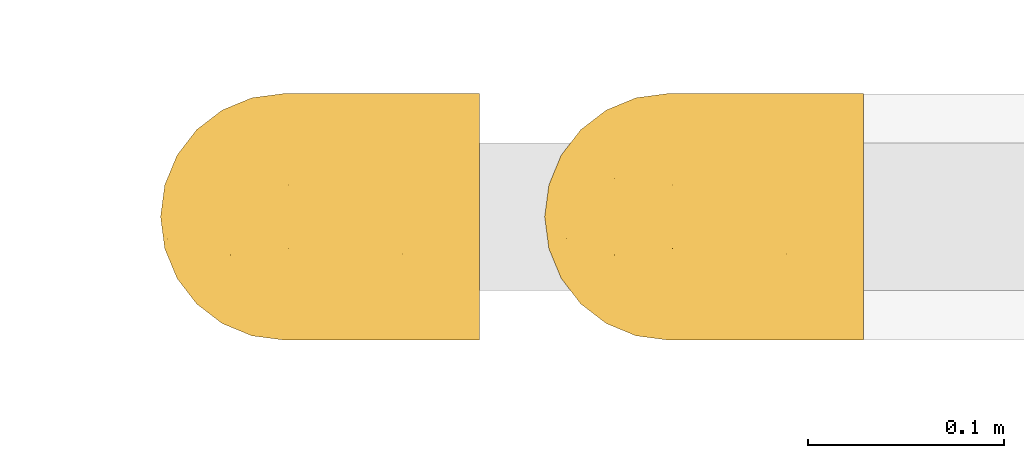
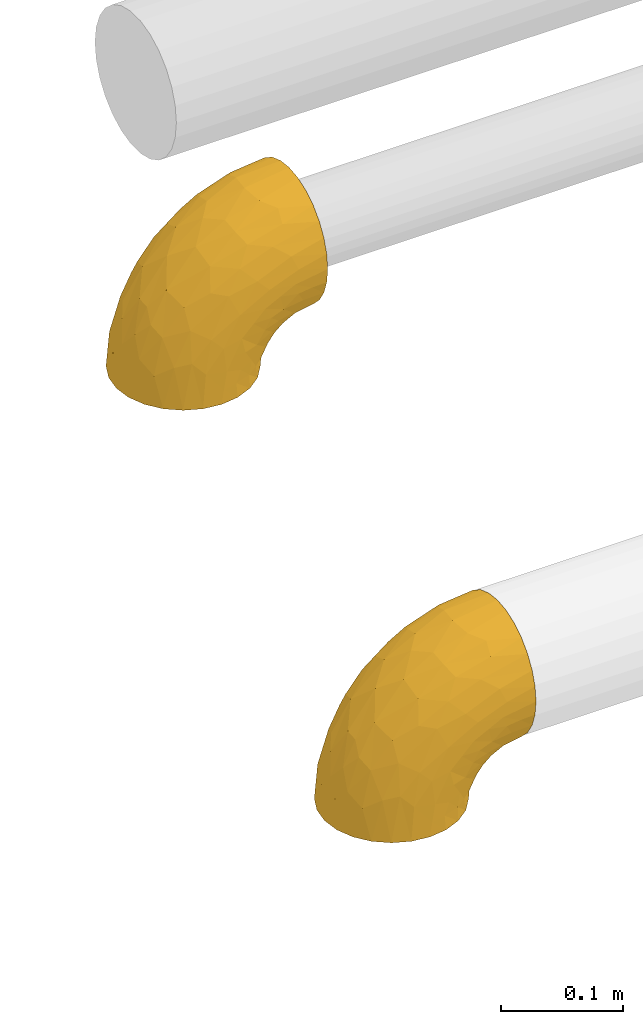
# One storey, part 119 of 827: 2 coverings.
"""IFC2X3 building model written with IfcOpenShell, lengths in millimetres."""

from ifc_helpers import new_model, entity, si_unit, converted_unit, derived_unit, direction, frame, origin, place, context, subcontext, project, spatial, faceted_brep, element, save


model = new_model("IFC2X3")

# Units and contexts
model_context = context("Model", 3, precision=0.01, world=origin(), true_north=direction((6.12303176911189e-17, 1.0)))
body_context = subcontext(model_context, "Body", "Model", "MODEL_VIEW")
ifc_project = project(units=[si_unit("LENGTHUNIT", "METRE", prefix="MILLI"), si_unit("AREAUNIT", "SQUARE_METRE"), si_unit("VOLUMEUNIT", "CUBIC_METRE"), converted_unit("PLANEANGLEUNIT", "DEGREE", entity("IfcRatioMeasure", 0.0174532925199433), si_unit("PLANEANGLEUNIT", "RADIAN"), dimensions=[0, 0, 0, 0, 0, 0, 0]), si_unit("MASSUNIT", "GRAM", prefix="KILO"), derived_unit("MASSDENSITYUNIT", [(si_unit("MASSUNIT", "GRAM", prefix="KILO"), 1), (si_unit("LENGTHUNIT", "METRE"), -3)]), derived_unit("MOMENTOFINERTIAUNIT", [(si_unit("LENGTHUNIT", "METRE"), 4)]), si_unit("TIMEUNIT", "SECOND"), si_unit("FREQUENCYUNIT", "HERTZ"), si_unit("THERMODYNAMICTEMPERATUREUNIT", "DEGREE_CELSIUS"), derived_unit("THERMALTRANSMITTANCEUNIT", [(si_unit("MASSUNIT", "GRAM", prefix="KILO"), 1), (si_unit("THERMODYNAMICTEMPERATUREUNIT", "KELVIN"), -1), (si_unit("TIMEUNIT", "SECOND"), -3)]), derived_unit("VOLUMETRICFLOWRATEUNIT", [(si_unit("LENGTHUNIT", "METRE"), 3), (si_unit("TIMEUNIT", "SECOND"), -1)]), derived_unit("MASSFLOWRATEUNIT", [(si_unit("MASSUNIT", "GRAM", prefix="KILO"), 1), (si_unit("TIMEUNIT", "SECOND"), -1)]), derived_unit("ROTATIONALFREQUENCYUNIT", [(si_unit("TIMEUNIT", "SECOND"), -1)]), si_unit("ELECTRICCURRENTUNIT", "AMPERE"), si_unit("ELECTRICVOLTAGEUNIT", "VOLT"), si_unit("POWERUNIT", "WATT"), si_unit("FORCEUNIT", "NEWTON", prefix="KILO"), si_unit("ILLUMINANCEUNIT", "LUX"), si_unit("LUMINOUSFLUXUNIT", "LUMEN"), si_unit("LUMINOUSINTENSITYUNIT", "CANDELA"), derived_unit("USERDEFINED", [(si_unit("MASSUNIT", "GRAM", prefix="KILO"), -1), (si_unit("LENGTHUNIT", "METRE"), -2), (si_unit("TIMEUNIT", "SECOND"), 3), (si_unit("LUMINOUSFLUXUNIT", "LUMEN"), 1)]), derived_unit("LINEARVELOCITYUNIT", [(si_unit("LENGTHUNIT", "METRE"), 1), (si_unit("TIMEUNIT", "SECOND"), -1)]), si_unit("PRESSUREUNIT", "PASCAL"), derived_unit("USERDEFINED", [(si_unit("LENGTHUNIT", "METRE"), -2), (si_unit("MASSUNIT", "GRAM", prefix="KILO"), 1), (si_unit("TIMEUNIT", "SECOND"), -2)]), derived_unit("LINEARFORCEUNIT", [(si_unit("MASSUNIT", "GRAM", prefix="KILO"), 1), (si_unit("LENGTHUNIT", "METRE"), 1), (si_unit("TIMEUNIT", "SECOND"), -2), (si_unit("LENGTHUNIT", "METRE"), -1)]), derived_unit("PLANARFORCEUNIT", [(si_unit("MASSUNIT", "GRAM", prefix="KILO"), 1), (si_unit("LENGTHUNIT", "METRE"), 1), (si_unit("TIMEUNIT", "SECOND"), -2), (si_unit("LENGTHUNIT", "METRE"), -2)])], contexts=[model_context])

# Site, building, storey
site_placement = place(None, origin())
site = spatial("IfcSite", under=ifc_project, at=site_placement, CompositionType="ELEMENT")
building_placement = place(site_placement, origin())
building = spatial("IfcBuilding", under=site, at=building_placement, CompositionType="ELEMENT")
storey_placement = place(building_placement, frame((0.0, 0.0, 28200.0)))
storey = spatial("IfcBuildingStorey", under=building, at=storey_placement, Name="08", CompositionType="ELEMENT", Elevation=28200.0)

# Coverings
covering_1_placement = place(storey_placement, frame((24847.71, 12005.41, 2998.4)))
element("IfcCovering", 1, at=covering_1_placement, inside=storey, Name=":ADSK_", ObjectType=":ADSK_", PredefinedType="INSULATION", context=body_context, shape_type="Brep", body=[
    faceted_brep([(164.6, 126.02, 115.61), (164.6, 121.36, 128.93), (164.6, 113.85, 140.87), (164.6, 103.88, 150.85), (164.6, 91.93, 158.35), (164.6, 78.62, 163.01), (164.6, 64.6, 164.6), (164.6, 50.58, 163.02), (164.6, 37.26, 158.36), (164.6, 25.32, 150.85), (164.6, 15.34, 140.88), (164.6, 7.84, 128.93), (164.6, 3.18, 115.62), (164.6, 1.6, 101.6), (164.6, 3.17, 87.58), (164.6, 7.83, 74.26), (164.6, 15.34, 62.32), (164.6, 25.31, 52.34), (164.6, 37.26, 44.84), (164.6, 50.57, 40.18), (164.6, 64.6, 38.6), (164.6, 78.61, 40.17), (164.6, 91.93, 44.83), (164.6, 103.87, 52.34), (164.6, 113.85, 62.31), (164.6, 121.35, 74.26), (164.6, 126.01, 87.57), (164.6, 127.6, 101.6), (96.1, 10.04, 1.6), (80.9, 3.74, 1.6), (75.83, 3.07, 1.6), (64.6, 1.6, 1.6), (48.29, 3.74, 1.6), (33.1, 10.04, 1.6), (20.05, 20.05, 1.6), (10.04, 33.1, 1.6), (3.74, 48.29, 1.6), (1.6, 64.6, 1.6), (3.74, 80.9, 1.6), (10.04, 96.1, 1.6), (20.05, 109.14, 1.6), (33.1, 119.15, 1.6), (48.29, 125.45, 1.6), (64.6, 127.6, 1.6), (75.83, 126.12, 1.6), (80.9, 125.45, 1.6), (96.1, 119.15, 1.6), (109.14, 109.14, 1.6), (119.15, 96.1, 1.6), (125.45, 80.9, 1.6), (127.6, 64.6, 1.6), (125.45, 48.29, 1.6), (119.15, 33.1, 1.6), (109.14, 20.05, 1.6), (16.11, 101.1, 30.9), (10.47, 86.73, 40.61), (25.17, 98.8, 64.38), (5.03, 75.9, 29.46), (7.15, 64.6, 43.78), (89.92, 113.69, 119.4), (63.64, 110.85, 102.55), (69.58, 99.57, 120.75), (37.4, 84.14, 98.48), (23.43, 64.6, 83.1), (49.34, 64.6, 116.85), (57.66, 122.7, 65.06), (41.13, 119.49, 45.15), (43.56, 112.73, 73.23), (51.24, 124.96, 34.45), (67.11, 126.54, 55.71), (101.38, 105.89, 134.95), (96.89, 93.87, 141.9), (127.01, 96.07, 151.53), (20.7, 87.21, 68.77), (13.5, 75.76, 60.03), (28.72, 112.0, 41.05), (122.41, 64.6, 159.04), (125.37, 83.57, 156.79), (67.01, 80.87, 129.47), (94.82, 78.22, 147.25), (76.34, 118.8, 99.9), (138.01, 126.55, 109.79), (133.22, 122.6, 122.17), (83.69, 127.6, 60.37), (76.59, 127.6, 46.44), (69.49, 127.6, 32.5), (83.16, 125.74, 83.03), (133.67, 107.12, 144.78), (119.86, 115.11, 131.77), (43.48, 102.74, 90.32), (105.82, 127.6, 82.5), (94.76, 127.6, 71.44), (150.96, 127.6, 99.44), (133.69, 127.6, 96.7), (110.48, 126.54, 99.08), (119.76, 127.6, 89.6), (101.13, 122.7, 108.53), (83.1, 64.6, 142.76), (66.76, 127.6, 15.23), (136.91, 79.61, 28.8), (142.02, 92.39, 38.73), (150.15, 78.62, 37.37), (79.29, 126.16, 16.7), (96.09, 122.25, 31.13), (87.81, 126.45, 44.73), (99.92, 123.85, 46.24), (83.57, 125.85, 28.2), (131.18, 97.8, 33.87), (123.5, 111.99, 43.22), (135.55, 104.61, 43.92), (152.5, 113.13, 60.19), (147.78, 103.95, 49.54), (137.69, 117.37, 61.42), (106.96, 124.82, 59.23), (116.2, 119.63, 51.24), (124.83, 95.72, 23.13), (122.46, 91.83, 11.1), (112.17, 109.35, 20.27), (94.66, 120.79, 16.61), (128.78, 80.16, 16.9), (130.07, 64.6, 10.85), (144.19, 122.83, 74.77), (137.7, 126.5, 85.72), (150.62, 126.15, 87.06), (146.1, 64.6, 33.64), (121.85, 121.73, 61.33), (112.08, 126.09, 70.11), (124.43, 125.23, 74.11), (157.98, 64.6, 36.82), (110.72, 116.48, 36.63), (119.91, 107.17, 31.12), (130.41, 114.56, 52.87), (153.66, 89.7, 42.37), (139.32, 64.6, 26.87), (132.55, 64.6, 20.1), (103.35, 116.12, 19.29), (112.17, 19.84, 20.28), (116.21, 9.56, 51.25), (110.7, 12.7, 36.64), (123.5, 17.2, 43.22), (128.77, 49.03, 16.9), (66.76, 1.6, 15.23), (150.15, 50.57, 37.37), (136.91, 49.58, 28.8), (137.69, 11.81, 61.43), (124.43, 3.96, 74.11), (121.85, 7.46, 61.34), (83.69, 1.6, 60.37), (76.59, 1.6, 46.44), (87.81, 2.74, 44.71), (130.41, 14.63, 52.87), (83.57, 3.34, 28.2), (96.09, 6.94, 31.13), (103.35, 13.07, 19.29), (122.46, 37.36, 11.1), (94.66, 8.4, 16.61), (79.29, 3.03, 16.7), (135.54, 24.58, 43.93), (131.17, 31.39, 33.87), (142.02, 36.79, 38.74), (153.66, 39.49, 42.37), (119.89, 22.01, 31.12), (150.96, 1.6, 99.44), (147.78, 25.23, 49.54), (112.07, 3.09, 70.12), (106.97, 4.37, 59.22), (144.19, 6.36, 74.78), (152.5, 16.06, 60.2), (124.83, 33.47, 23.13), (133.69, 1.6, 96.7), (150.62, 3.04, 87.06), (137.71, 2.69, 85.72), (105.82, 1.6, 82.5), (94.76, 1.6, 71.44), (99.9, 5.34, 46.25), (119.76, 1.6, 89.6), (69.49, 1.6, 32.5), (25.17, 30.39, 64.38), (16.11, 28.09, 30.9), (28.72, 17.19, 41.05), (41.13, 9.71, 45.15), (10.47, 42.46, 40.61), (12.64, 53.42, 57.76), (5.01, 53.33, 29.39), (67.11, 2.65, 55.71), (138.01, 2.64, 109.79), (133.22, 6.59, 122.17), (101.13, 6.49, 108.53), (63.64, 18.34, 102.55), (89.92, 15.51, 119.41), (69.57, 29.62, 120.74), (110.48, 2.65, 99.08), (83.16, 3.45, 83.03), (51.24, 4.23, 34.45), (21.38, 42.8, 70.91), (101.38, 23.3, 134.95), (133.67, 22.08, 144.78), (96.89, 35.32, 141.9), (135.87, 33.03, 153.43), (119.86, 14.08, 131.77), (43.56, 16.47, 73.23), (67.01, 48.32, 129.47), (37.4, 45.05, 98.48), (76.35, 10.39, 99.91), (57.66, 6.49, 65.06), (43.48, 26.45, 90.32), (125.37, 45.62, 156.79), (94.76, 48.44, 146.54), (23.91, 53.12, 81.81)], [[[0, 1, 2, 3, 4, 5, 6, 7, 8, 9, 10, 11, 12, 13, 14, 15, 16, 17, 18, 19, 20, 21, 22, 23, 24, 25, 26, 27]], [[28, 29, 30, 31, 32, 33, 34, 35, 36, 37, 38, 39, 40, 41, 42, 43, 44, 45, 46, 47, 48, 49, 50, 51, 52, 53]], [[54, 55, 56]], [[57, 37, 58]], [[59, 60, 61]], [[62, 63, 64]], [[65, 66, 67]], [[68, 65, 69]], [[70, 71, 72]], [[55, 73, 56]], [[39, 38, 55]], [[55, 74, 73]], [[75, 40, 54]], [[40, 39, 54]], [[76, 5, 77]], [[71, 78, 79]], [[41, 75, 66]], [[42, 68, 43]], [[59, 80, 60]], [[0, 81, 82]], [[69, 83, 84, 85]], [[69, 86, 83]], [[82, 1, 0]], [[2, 87, 3]], [[4, 3, 72]], [[40, 75, 41]], [[5, 4, 77]], [[2, 1, 88]], [[72, 3, 87]], [[5, 76, 6]], [[70, 87, 88]], [[68, 66, 65]], [[87, 2, 88]], [[56, 89, 67]], [[78, 62, 64]], [[86, 90, 91, 83]], [[81, 27, 92, 93]], [[62, 61, 89]], [[94, 93, 95, 90]], [[96, 94, 86]], [[38, 57, 55]], [[78, 61, 62]], [[82, 88, 1]], [[78, 64, 97]], [[57, 74, 55]], [[76, 77, 79]], [[77, 72, 71]], [[80, 86, 65]], [[94, 81, 93]], [[96, 88, 82]], [[79, 78, 97]], [[61, 71, 70]], [[86, 94, 90]], [[81, 96, 82]], [[68, 85, 98, 43]], [[86, 69, 65]], [[68, 69, 85]], [[66, 42, 41]], [[66, 68, 42]], [[67, 66, 75]], [[56, 67, 75]], [[67, 60, 80]], [[59, 70, 88]], [[70, 59, 61]], [[60, 67, 89]], [[78, 71, 61]], [[81, 94, 96]], [[27, 81, 0]], [[88, 96, 59]], [[80, 59, 96]], [[86, 80, 96]], [[67, 80, 65]], [[62, 89, 56]], [[61, 60, 89]], [[55, 54, 39]], [[75, 54, 56]], [[37, 57, 38]], [[74, 57, 58]], [[58, 63, 74]], [[62, 74, 63]], [[74, 62, 73]], [[62, 56, 73]], [[4, 72, 77]], [[70, 72, 87]], [[76, 79, 97]], [[71, 79, 77]], [[99, 100, 101]], [[98, 85, 102]], [[103, 104, 105]], [[106, 102, 85]], [[107, 108, 109]], [[106, 85, 84]], [[110, 111, 112]], [[105, 113, 114]], [[115, 116, 117]], [[47, 46, 118]], [[49, 119, 120]], [[48, 47, 117]], [[121, 122, 123]], [[123, 92, 26]], [[48, 116, 49]], [[124, 99, 101]], [[125, 126, 127]], [[127, 121, 112]], [[25, 24, 121]], [[101, 128, 124]], [[117, 129, 130]], [[26, 25, 123]], [[27, 26, 92]], [[131, 109, 108]], [[127, 95, 122]], [[24, 110, 121]], [[21, 20, 128]], [[131, 108, 114]], [[44, 43, 98, 45]], [[129, 114, 108]], [[23, 110, 24]], [[119, 115, 99]], [[101, 132, 21]], [[111, 23, 22]], [[90, 126, 91]], [[99, 124, 133, 134]], [[132, 111, 22]], [[128, 101, 21]], [[135, 47, 118]], [[101, 100, 132]], [[119, 99, 134]], [[107, 99, 115]], [[125, 114, 113]], [[93, 123, 122]], [[112, 125, 127]], [[129, 105, 114]], [[127, 90, 95]], [[120, 50, 49]], [[116, 119, 49]], [[111, 110, 23]], [[121, 110, 112]], [[111, 132, 100]], [[21, 132, 22]], [[125, 112, 131]], [[126, 125, 113]], [[112, 111, 131]], [[109, 111, 100]], [[111, 109, 131]], [[107, 109, 100]], [[99, 107, 100]], [[107, 115, 130]], [[126, 113, 91]], [[90, 127, 126]], [[131, 114, 125]], [[130, 129, 108]], [[135, 129, 117]], [[129, 103, 105]], [[107, 130, 108]], [[117, 130, 115]], [[121, 123, 25]], [[92, 123, 93]], [[127, 122, 121]], [[95, 93, 122]], [[117, 116, 48]], [[119, 116, 115]], [[84, 104, 106]], [[83, 113, 105]], [[103, 118, 106]], [[105, 104, 83]], [[102, 46, 45]], [[106, 104, 103]], [[83, 104, 84]], [[118, 103, 135]], [[102, 118, 46]], [[129, 135, 103]], [[47, 135, 117]], [[102, 106, 118]], [[98, 102, 45]], [[113, 83, 91]], [[119, 134, 120]], [[53, 52, 136]], [[137, 138, 139]], [[51, 120, 140]], [[141, 31, 30, 29]], [[19, 142, 128]], [[143, 134, 133, 124]], [[144, 145, 146]], [[147, 148, 149]], [[150, 144, 146]], [[151, 152, 149]], [[153, 53, 136]], [[52, 154, 136]], [[28, 155, 156]], [[143, 140, 134]], [[157, 158, 159]], [[124, 142, 143]], [[124, 128, 142]], [[18, 160, 19]], [[138, 161, 139]], [[14, 13, 162]], [[156, 141, 29]], [[159, 160, 163]], [[18, 17, 163]], [[164, 165, 146]], [[51, 154, 52]], [[166, 145, 144]], [[157, 163, 150]], [[166, 144, 167]], [[167, 17, 16]], [[16, 15, 166]], [[136, 168, 161]], [[162, 169, 170]], [[15, 14, 170]], [[167, 163, 17]], [[19, 128, 20]], [[171, 145, 166]], [[160, 159, 142]], [[155, 153, 152]], [[170, 166, 15]], [[142, 159, 143]], [[158, 143, 159]], [[140, 143, 168]], [[154, 140, 168]], [[164, 172, 173]], [[138, 174, 152]], [[150, 146, 137]], [[166, 170, 171]], [[175, 172, 145]], [[166, 167, 16]], [[163, 167, 144]], [[19, 160, 142]], [[163, 160, 18]], [[164, 146, 145]], [[137, 146, 165]], [[157, 150, 139]], [[163, 144, 150]], [[139, 161, 158]], [[163, 157, 159]], [[139, 158, 157]], [[143, 158, 168]], [[145, 172, 164]], [[164, 173, 165]], [[174, 138, 137]], [[150, 137, 139]], [[174, 137, 165]], [[153, 138, 152]], [[136, 161, 138]], [[158, 161, 168]], [[162, 170, 14]], [[170, 169, 171]], [[169, 175, 171]], [[145, 171, 175]], [[140, 154, 51]], [[136, 154, 168]], [[165, 147, 174]], [[174, 149, 152]], [[156, 151, 176]], [[151, 148, 176]], [[155, 152, 151]], [[147, 149, 174]], [[151, 149, 148]], [[156, 155, 151]], [[53, 155, 28]], [[53, 153, 155]], [[138, 153, 136]], [[141, 156, 176]], [[28, 156, 29]], [[120, 51, 50]], [[147, 165, 173]], [[120, 134, 140]], [[177, 178, 179]], [[33, 32, 180]], [[181, 182, 183]], [[184, 176, 148, 147]], [[185, 186, 187]], [[188, 189, 190]], [[191, 192, 172]], [[184, 193, 176]], [[194, 181, 177]], [[193, 180, 32]], [[37, 36, 183]], [[195, 196, 197]], [[9, 8, 198]], [[178, 181, 35]], [[36, 35, 181]], [[33, 179, 34]], [[189, 199, 195]], [[193, 31, 141, 176]], [[35, 34, 178]], [[186, 11, 199]], [[192, 147, 173, 172]], [[179, 180, 200]], [[201, 64, 202]], [[179, 200, 177]], [[13, 12, 185]], [[203, 187, 189]], [[12, 11, 186]], [[184, 192, 204]], [[203, 192, 187]], [[10, 199, 11]], [[177, 200, 205]], [[206, 198, 8]], [[207, 201, 197]], [[63, 208, 64]], [[7, 206, 8]], [[194, 182, 181]], [[7, 6, 76]], [[199, 196, 195]], [[196, 10, 9]], [[197, 196, 198]], [[7, 76, 206]], [[10, 196, 199]], [[207, 76, 97]], [[191, 172, 175, 169]], [[64, 201, 97]], [[63, 58, 182]], [[199, 187, 186]], [[187, 191, 185]], [[177, 205, 202]], [[207, 197, 206]], [[192, 184, 147]], [[193, 184, 204]], [[193, 204, 180]], [[31, 193, 32]], [[204, 203, 200]], [[33, 180, 179]], [[204, 200, 180]], [[200, 188, 205]], [[191, 169, 185]], [[192, 191, 187]], [[190, 195, 197]], [[195, 190, 189]], [[197, 201, 190]], [[202, 190, 201]], [[185, 169, 162, 13]], [[186, 185, 12]], [[203, 189, 188]], [[187, 199, 189]], [[200, 203, 188]], [[192, 203, 204]], [[188, 190, 205]], [[202, 205, 190]], [[179, 178, 34]], [[181, 178, 177]], [[177, 202, 194]], [[182, 208, 63]], [[182, 194, 208]], [[183, 182, 58]], [[37, 183, 58]], [[181, 183, 36]], [[194, 202, 208]], [[64, 208, 202]], [[197, 198, 206]], [[9, 198, 196]], [[76, 207, 206]], [[97, 201, 207]]]),
])
covering_2_placement = place(storey_placement, frame((25044.13, 12005.41, 2498.4)))
element("IfcCovering", 2, at=covering_2_placement, inside=storey, Name=":ADSK_", ObjectType=":ADSK_", PredefinedType="INSULATION", context=body_context, shape_type="Brep", body=[
    faceted_brep([(164.6, 126.02, 115.61), (164.6, 121.36, 128.93), (164.6, 113.85, 140.87), (164.6, 103.88, 150.85), (164.6, 91.93, 158.35), (164.6, 78.62, 163.01), (164.6, 64.6, 164.6), (164.6, 50.58, 163.02), (164.6, 37.26, 158.36), (164.6, 25.32, 150.85), (164.6, 15.34, 140.88), (164.6, 7.84, 128.93), (164.6, 3.18, 115.62), (164.6, 1.6, 101.6), (164.6, 3.17, 87.58), (164.6, 7.83, 74.26), (164.6, 15.34, 62.32), (164.6, 25.31, 52.34), (164.6, 37.26, 44.84), (164.6, 50.57, 40.18), (164.6, 64.6, 38.6), (164.6, 78.61, 40.17), (164.6, 91.93, 44.83), (164.6, 103.87, 52.34), (164.6, 113.85, 62.31), (164.6, 121.35, 74.26), (164.6, 126.01, 87.57), (164.6, 127.6, 101.6), (96.1, 10.04, 1.6), (80.9, 3.74, 1.6), (75.83, 3.07, 1.6), (64.6, 1.6, 1.6), (48.29, 3.74, 1.6), (33.1, 10.04, 1.6), (20.05, 20.05, 1.6), (10.04, 33.1, 1.6), (3.74, 48.29, 1.6), (1.6, 64.6, 1.6), (3.74, 80.9, 1.6), (10.04, 96.1, 1.6), (20.05, 109.14, 1.6), (33.1, 119.15, 1.6), (48.29, 125.45, 1.6), (64.6, 127.6, 1.6), (75.83, 126.12, 1.6), (80.9, 125.45, 1.6), (96.1, 119.15, 1.6), (109.14, 109.14, 1.6), (119.15, 96.1, 1.6), (125.45, 80.9, 1.6), (127.6, 64.6, 1.6), (125.45, 48.29, 1.6), (119.15, 33.1, 1.6), (109.14, 20.05, 1.6), (16.11, 101.1, 30.9), (10.47, 86.73, 40.61), (25.17, 98.8, 64.38), (5.03, 75.9, 29.46), (7.15, 64.6, 43.78), (89.92, 113.69, 119.4), (63.64, 110.85, 102.55), (69.58, 99.57, 120.75), (37.4, 84.14, 98.48), (23.43, 64.6, 83.1), (49.34, 64.6, 116.85), (57.66, 122.7, 65.06), (41.13, 119.49, 45.15), (43.56, 112.73, 73.23), (51.24, 124.96, 34.45), (67.11, 126.54, 55.71), (101.38, 105.89, 134.95), (96.89, 93.87, 141.9), (127.01, 96.07, 151.53), (20.7, 87.21, 68.77), (13.5, 75.76, 60.03), (28.72, 112.0, 41.05), (122.41, 64.6, 159.04), (125.37, 83.57, 156.79), (67.01, 80.87, 129.47), (94.82, 78.22, 147.25), (76.34, 118.8, 99.9), (138.01, 126.55, 109.79), (133.22, 122.6, 122.17), (83.69, 127.6, 60.37), (76.59, 127.6, 46.44), (69.49, 127.6, 32.5), (83.16, 125.74, 83.03), (133.67, 107.12, 144.78), (119.86, 115.11, 131.77), (43.48, 102.74, 90.32), (105.82, 127.6, 82.5), (94.76, 127.6, 71.44), (150.96, 127.6, 99.44), (133.69, 127.6, 96.7), (110.48, 126.54, 99.08), (119.76, 127.6, 89.6), (101.13, 122.7, 108.53), (83.1, 64.6, 142.76), (66.76, 127.6, 15.23), (136.91, 79.61, 28.8), (142.02, 92.39, 38.73), (150.15, 78.62, 37.37), (79.29, 126.16, 16.7), (96.09, 122.25, 31.13), (87.81, 126.45, 44.73), (99.92, 123.85, 46.24), (83.57, 125.85, 28.2), (131.18, 97.8, 33.87), (123.5, 111.99, 43.22), (135.55, 104.61, 43.92), (152.5, 113.13, 60.19), (147.78, 103.95, 49.54), (137.69, 117.37, 61.42), (106.96, 124.82, 59.23), (116.2, 119.63, 51.24), (124.83, 95.72, 23.13), (122.46, 91.83, 11.1), (112.17, 109.35, 20.27), (94.66, 120.79, 16.61), (128.78, 80.16, 16.9), (130.07, 64.6, 10.85), (144.19, 122.83, 74.77), (137.7, 126.5, 85.72), (150.62, 126.15, 87.06), (146.1, 64.6, 33.64), (121.85, 121.73, 61.33), (112.08, 126.09, 70.11), (124.43, 125.23, 74.11), (157.98, 64.6, 36.82), (110.72, 116.48, 36.63), (119.91, 107.17, 31.12), (130.41, 114.56, 52.87), (153.66, 89.7, 42.37), (139.32, 64.6, 26.87), (132.55, 64.6, 20.1), (103.35, 116.12, 19.29), (112.17, 19.84, 20.28), (116.21, 9.56, 51.25), (110.7, 12.7, 36.64), (123.5, 17.2, 43.22), (128.77, 49.03, 16.9), (66.76, 1.6, 15.23), (150.15, 50.57, 37.37), (136.91, 49.58, 28.8), (137.69, 11.81, 61.43), (124.43, 3.96, 74.11), (121.85, 7.46, 61.34), (83.69, 1.6, 60.37), (76.59, 1.6, 46.44), (87.81, 2.74, 44.71), (130.41, 14.63, 52.87), (83.57, 3.34, 28.2), (96.09, 6.94, 31.13), (103.35, 13.07, 19.29), (122.46, 37.36, 11.1), (94.66, 8.4, 16.61), (79.29, 3.03, 16.7), (135.54, 24.58, 43.93), (131.17, 31.39, 33.87), (142.02, 36.79, 38.74), (153.66, 39.49, 42.37), (119.89, 22.01, 31.12), (150.96, 1.6, 99.44), (147.78, 25.23, 49.54), (112.07, 3.09, 70.12), (106.97, 4.37, 59.22), (144.19, 6.36, 74.78), (152.5, 16.06, 60.2), (124.83, 33.47, 23.13), (133.69, 1.6, 96.7), (150.62, 3.04, 87.06), (137.71, 2.69, 85.72), (105.82, 1.6, 82.5), (94.76, 1.6, 71.44), (99.9, 5.34, 46.25), (119.76, 1.6, 89.6), (69.49, 1.6, 32.5), (25.17, 30.39, 64.38), (16.11, 28.09, 30.9), (28.72, 17.19, 41.05), (41.13, 9.71, 45.15), (10.47, 42.46, 40.61), (12.64, 53.42, 57.76), (5.01, 53.33, 29.39), (67.11, 2.65, 55.71), (138.01, 2.64, 109.79), (133.22, 6.59, 122.17), (101.13, 6.49, 108.53), (63.64, 18.34, 102.55), (89.92, 15.51, 119.41), (69.57, 29.62, 120.74), (110.48, 2.65, 99.08), (83.16, 3.45, 83.03), (51.24, 4.23, 34.45), (21.38, 42.8, 70.91), (101.38, 23.3, 134.95), (133.67, 22.08, 144.78), (96.89, 35.32, 141.9), (135.87, 33.03, 153.43), (119.86, 14.08, 131.77), (43.56, 16.47, 73.23), (67.01, 48.32, 129.47), (37.4, 45.05, 98.48), (76.35, 10.39, 99.91), (57.66, 6.49, 65.06), (43.48, 26.45, 90.32), (125.37, 45.62, 156.79), (94.76, 48.44, 146.54), (23.91, 53.12, 81.81)], [[[0, 1, 2, 3, 4, 5, 6, 7, 8, 9, 10, 11, 12, 13, 14, 15, 16, 17, 18, 19, 20, 21, 22, 23, 24, 25, 26, 27]], [[28, 29, 30, 31, 32, 33, 34, 35, 36, 37, 38, 39, 40, 41, 42, 43, 44, 45, 46, 47, 48, 49, 50, 51, 52, 53]], [[54, 55, 56]], [[57, 37, 58]], [[59, 60, 61]], [[62, 63, 64]], [[65, 66, 67]], [[68, 65, 69]], [[70, 71, 72]], [[55, 73, 56]], [[39, 38, 55]], [[55, 74, 73]], [[75, 40, 54]], [[40, 39, 54]], [[76, 5, 77]], [[71, 78, 79]], [[41, 75, 66]], [[42, 68, 43]], [[59, 80, 60]], [[0, 81, 82]], [[69, 83, 84, 85]], [[69, 86, 83]], [[82, 1, 0]], [[2, 87, 3]], [[4, 3, 72]], [[40, 75, 41]], [[5, 4, 77]], [[2, 1, 88]], [[72, 3, 87]], [[5, 76, 6]], [[70, 87, 88]], [[68, 66, 65]], [[87, 2, 88]], [[56, 89, 67]], [[78, 62, 64]], [[86, 90, 91, 83]], [[81, 27, 92, 93]], [[62, 61, 89]], [[94, 93, 95, 90]], [[96, 94, 86]], [[38, 57, 55]], [[78, 61, 62]], [[82, 88, 1]], [[78, 64, 97]], [[57, 74, 55]], [[76, 77, 79]], [[77, 72, 71]], [[80, 86, 65]], [[94, 81, 93]], [[96, 88, 82]], [[79, 78, 97]], [[61, 71, 70]], [[86, 94, 90]], [[81, 96, 82]], [[68, 85, 98, 43]], [[86, 69, 65]], [[68, 69, 85]], [[66, 42, 41]], [[66, 68, 42]], [[67, 66, 75]], [[56, 67, 75]], [[67, 60, 80]], [[59, 70, 88]], [[70, 59, 61]], [[60, 67, 89]], [[78, 71, 61]], [[81, 94, 96]], [[27, 81, 0]], [[88, 96, 59]], [[80, 59, 96]], [[86, 80, 96]], [[67, 80, 65]], [[62, 89, 56]], [[61, 60, 89]], [[55, 54, 39]], [[75, 54, 56]], [[37, 57, 38]], [[74, 57, 58]], [[58, 63, 74]], [[62, 74, 63]], [[74, 62, 73]], [[62, 56, 73]], [[4, 72, 77]], [[70, 72, 87]], [[76, 79, 97]], [[71, 79, 77]], [[99, 100, 101]], [[98, 85, 102]], [[103, 104, 105]], [[106, 102, 85]], [[107, 108, 109]], [[106, 85, 84]], [[110, 111, 112]], [[105, 113, 114]], [[115, 116, 117]], [[47, 46, 118]], [[49, 119, 120]], [[48, 47, 117]], [[121, 122, 123]], [[123, 92, 26]], [[48, 116, 49]], [[124, 99, 101]], [[125, 126, 127]], [[127, 121, 112]], [[25, 24, 121]], [[101, 128, 124]], [[117, 129, 130]], [[26, 25, 123]], [[27, 26, 92]], [[131, 109, 108]], [[127, 95, 122]], [[24, 110, 121]], [[21, 20, 128]], [[131, 108, 114]], [[44, 43, 98, 45]], [[129, 114, 108]], [[23, 110, 24]], [[119, 115, 99]], [[101, 132, 21]], [[111, 23, 22]], [[90, 126, 91]], [[99, 124, 133, 134]], [[132, 111, 22]], [[128, 101, 21]], [[135, 47, 118]], [[101, 100, 132]], [[119, 99, 134]], [[107, 99, 115]], [[125, 114, 113]], [[93, 123, 122]], [[112, 125, 127]], [[129, 105, 114]], [[127, 90, 95]], [[120, 50, 49]], [[116, 119, 49]], [[111, 110, 23]], [[121, 110, 112]], [[111, 132, 100]], [[21, 132, 22]], [[125, 112, 131]], [[126, 125, 113]], [[112, 111, 131]], [[109, 111, 100]], [[111, 109, 131]], [[107, 109, 100]], [[99, 107, 100]], [[107, 115, 130]], [[126, 113, 91]], [[90, 127, 126]], [[131, 114, 125]], [[130, 129, 108]], [[135, 129, 117]], [[129, 103, 105]], [[107, 130, 108]], [[117, 130, 115]], [[121, 123, 25]], [[92, 123, 93]], [[127, 122, 121]], [[95, 93, 122]], [[117, 116, 48]], [[119, 116, 115]], [[84, 104, 106]], [[83, 113, 105]], [[103, 118, 106]], [[105, 104, 83]], [[102, 46, 45]], [[106, 104, 103]], [[83, 104, 84]], [[118, 103, 135]], [[102, 118, 46]], [[129, 135, 103]], [[47, 135, 117]], [[102, 106, 118]], [[98, 102, 45]], [[113, 83, 91]], [[119, 134, 120]], [[53, 52, 136]], [[137, 138, 139]], [[51, 120, 140]], [[141, 31, 30, 29]], [[19, 142, 128]], [[143, 134, 133, 124]], [[144, 145, 146]], [[147, 148, 149]], [[150, 144, 146]], [[151, 152, 149]], [[153, 53, 136]], [[52, 154, 136]], [[28, 155, 156]], [[143, 140, 134]], [[157, 158, 159]], [[124, 142, 143]], [[124, 128, 142]], [[18, 160, 19]], [[138, 161, 139]], [[14, 13, 162]], [[156, 141, 29]], [[159, 160, 163]], [[18, 17, 163]], [[164, 165, 146]], [[51, 154, 52]], [[166, 145, 144]], [[157, 163, 150]], [[166, 144, 167]], [[167, 17, 16]], [[16, 15, 166]], [[136, 168, 161]], [[162, 169, 170]], [[15, 14, 170]], [[167, 163, 17]], [[19, 128, 20]], [[171, 145, 166]], [[160, 159, 142]], [[155, 153, 152]], [[170, 166, 15]], [[142, 159, 143]], [[158, 143, 159]], [[140, 143, 168]], [[154, 140, 168]], [[164, 172, 173]], [[138, 174, 152]], [[150, 146, 137]], [[166, 170, 171]], [[175, 172, 145]], [[166, 167, 16]], [[163, 167, 144]], [[19, 160, 142]], [[163, 160, 18]], [[164, 146, 145]], [[137, 146, 165]], [[157, 150, 139]], [[163, 144, 150]], [[139, 161, 158]], [[163, 157, 159]], [[139, 158, 157]], [[143, 158, 168]], [[145, 172, 164]], [[164, 173, 165]], [[174, 138, 137]], [[150, 137, 139]], [[174, 137, 165]], [[153, 138, 152]], [[136, 161, 138]], [[158, 161, 168]], [[162, 170, 14]], [[170, 169, 171]], [[169, 175, 171]], [[145, 171, 175]], [[140, 154, 51]], [[136, 154, 168]], [[165, 147, 174]], [[174, 149, 152]], [[156, 151, 176]], [[151, 148, 176]], [[155, 152, 151]], [[147, 149, 174]], [[151, 149, 148]], [[156, 155, 151]], [[53, 155, 28]], [[53, 153, 155]], [[138, 153, 136]], [[141, 156, 176]], [[28, 156, 29]], [[120, 51, 50]], [[147, 165, 173]], [[120, 134, 140]], [[177, 178, 179]], [[33, 32, 180]], [[181, 182, 183]], [[184, 176, 148, 147]], [[185, 186, 187]], [[188, 189, 190]], [[191, 192, 172]], [[184, 193, 176]], [[194, 181, 177]], [[193, 180, 32]], [[37, 36, 183]], [[195, 196, 197]], [[9, 8, 198]], [[178, 181, 35]], [[36, 35, 181]], [[33, 179, 34]], [[189, 199, 195]], [[193, 31, 141, 176]], [[35, 34, 178]], [[186, 11, 199]], [[192, 147, 173, 172]], [[179, 180, 200]], [[201, 64, 202]], [[179, 200, 177]], [[13, 12, 185]], [[203, 187, 189]], [[12, 11, 186]], [[184, 192, 204]], [[203, 192, 187]], [[10, 199, 11]], [[177, 200, 205]], [[206, 198, 8]], [[207, 201, 197]], [[63, 208, 64]], [[7, 206, 8]], [[194, 182, 181]], [[7, 6, 76]], [[199, 196, 195]], [[196, 10, 9]], [[197, 196, 198]], [[7, 76, 206]], [[10, 196, 199]], [[207, 76, 97]], [[191, 172, 175, 169]], [[64, 201, 97]], [[63, 58, 182]], [[199, 187, 186]], [[187, 191, 185]], [[177, 205, 202]], [[207, 197, 206]], [[192, 184, 147]], [[193, 184, 204]], [[193, 204, 180]], [[31, 193, 32]], [[204, 203, 200]], [[33, 180, 179]], [[204, 200, 180]], [[200, 188, 205]], [[191, 169, 185]], [[192, 191, 187]], [[190, 195, 197]], [[195, 190, 189]], [[197, 201, 190]], [[202, 190, 201]], [[185, 169, 162, 13]], [[186, 185, 12]], [[203, 189, 188]], [[187, 199, 189]], [[200, 203, 188]], [[192, 203, 204]], [[188, 190, 205]], [[202, 205, 190]], [[179, 178, 34]], [[181, 178, 177]], [[177, 202, 194]], [[182, 208, 63]], [[182, 194, 208]], [[183, 182, 58]], [[37, 183, 58]], [[181, 183, 36]], [[194, 202, 208]], [[64, 208, 202]], [[197, 198, 206]], [[9, 198, 196]], [[76, 207, 206]], [[97, 201, 207]]]),
])

save(model, "model.ifc")
